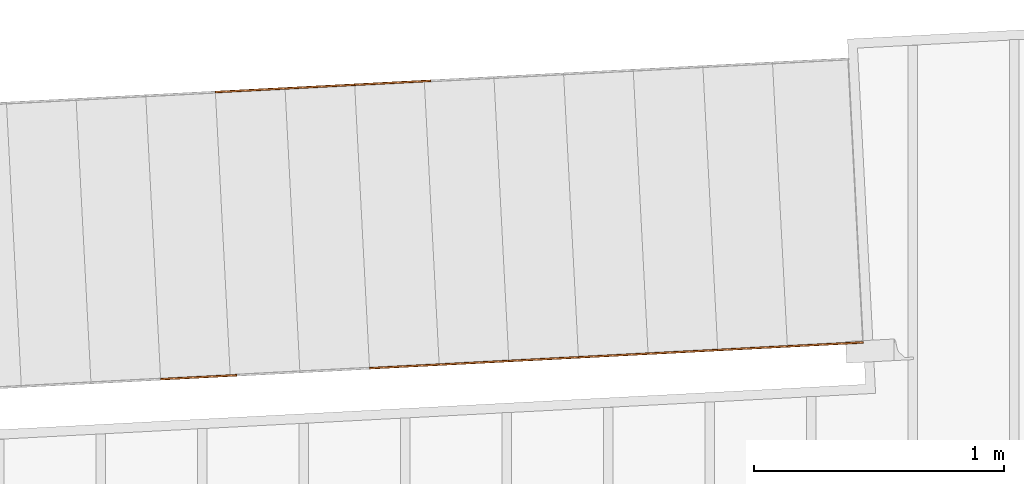
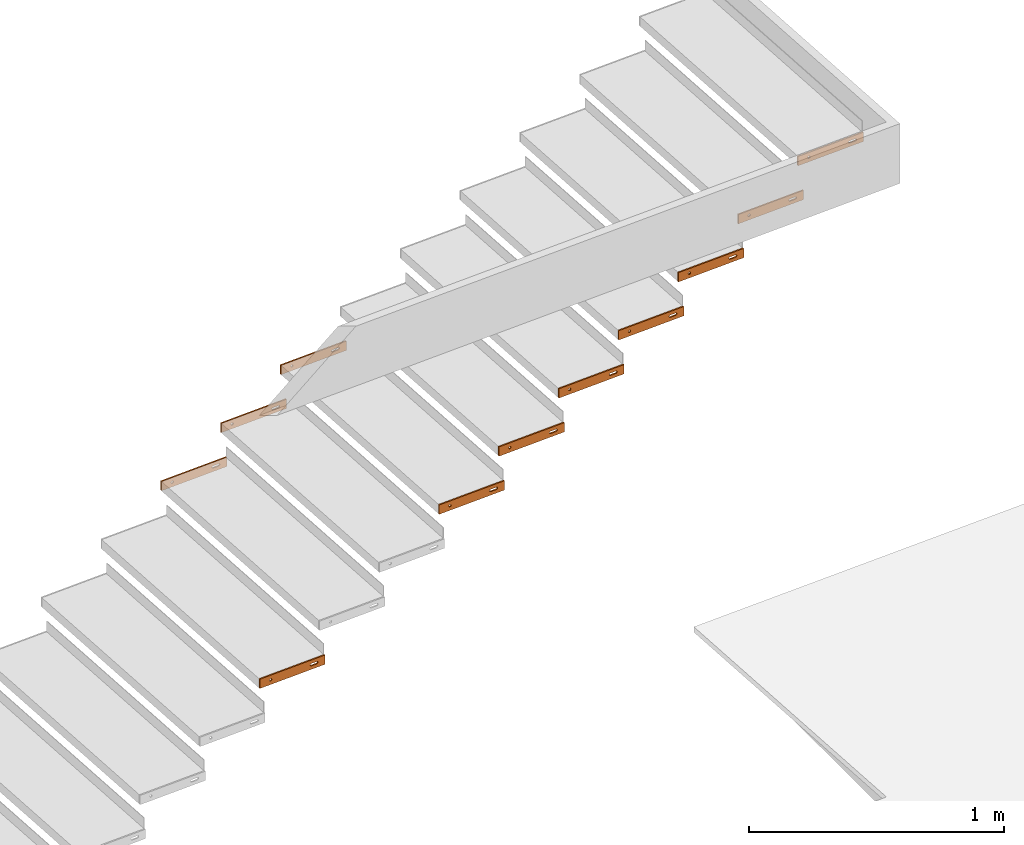
# One storey, part 18 of 23: 11 proxies.
"""IFC4 building model written with IfcOpenShell, lengths in feet."""

import ifcopenshell
import ifcopenshell.guid

model = None  # the IFC model being written
_history = None  # IfcOwnerHistory: only IFC2X3 demands one
_inside = {}  # id of a spatial element -> (the spatial element, [elements in it])
_under = {}  # id of a project, library or spatial element -> (it, [spatial elements below it])
_declared = {}  # id of a project -> (the project, [libraries it declares])
_typed = {}  # id of a type object -> (the type object, [elements of that type])
_made_of = {}  # id of a material, layer set ... -> (it, [elements and type objects made of it])


def new_model(schema):
    """Start an empty IFC model of exactly this schema.

    Asked for "IFC4X3", IfcOpenShell would pick the latest addendum, in which some entities
    have other attributes; the version numbers below select the first issue.
    IFC2X3 requires an IfcOwnerHistory on every rooted entity: one is made here for all.
    """
    global model, _history
    if schema == "IFC4X3":
        model = ifcopenshell.file(schema_version=(4, 3, 0, 0))
    else:
        model = ifcopenshell.file(schema=schema)
    _inside.clear()
    _under.clear()
    _declared.clear()
    _typed.clear()
    _made_of.clear()
    _history = None
    if model.schema == "IFC2X3":
        org = make("IfcOrganization", Name="unknown")
        user = make(
            "IfcPersonAndOrganization",
            ThePerson=make("IfcPerson", FamilyName="unknown"),
            TheOrganization=org,
        )
        app = make(
            "IfcApplication",
            ApplicationDeveloper=org,
            Version="unknown",
            ApplicationFullName="unknown",
            ApplicationIdentifier="unknown",
        )
        _history = make(
            "IfcOwnerHistory",
            OwningUser=user,
            OwningApplication=app,
            ChangeAction="ADDED",
            CreationDate=0,
        )
    return model


def make(cls, **values):
    """One entity of the class cls with the attributes given. An attribute that is None is left unset."""
    return model.create_entity(
        cls, **{name: value for name, value in values.items() if value is not None}
    )


def entity(cls, *values):
    """Any entity or typed value of the class cls, its attributes in the order of the schema. None: left unset."""
    e = model.create_entity(cls)
    for i, value in enumerate(values):
        if value is not None:
            e[i] = value
    return e


def rooted(cls, **values):
    """An entity with a GlobalId (a new one), such as an element, a storey or a relation."""
    return make(cls, GlobalId=ifcopenshell.guid.new(), OwnerHistory=_history, **values)


def si_unit(unit_type, name, prefix=None):
    """IfcSIUnit, for example si_unit("LENGTHUNIT", "METRE", prefix="MILLI")."""
    return make("IfcSIUnit", UnitType=unit_type, Prefix=prefix, Name=name)


def converted_unit(unit_type, name, factor, base, dimensions=None, offset=None):
    """IfcConversionBasedUnit, such as the inch: factor (a typed value) times the base unit."""
    return make(
        "IfcConversionBasedUnit"
        if offset is None
        else "IfcConversionBasedUnitWithOffset",
        ConversionOffset=offset,
        Dimensions=None
        if dimensions is None
        else entity("IfcDimensionalExponents", *dimensions),
        UnitType=unit_type,
        Name=name,
        ConversionFactor=make(
            "IfcMeasureWithUnit", ValueComponent=factor, UnitComponent=base
        ),
    )


def derived_unit(unit_type, elements):
    """IfcDerivedUnit: a product of units, each with its exponent."""
    return make(
        "IfcDerivedUnit",
        Elements=[
            make("IfcDerivedUnitElement", Unit=unit, Exponent=power)
            for unit, power in elements
        ],
        UnitType=unit_type,
    )


def assignment(units):
    """IfcUnitAssignment: the units of a project."""
    return None if units is None else make("IfcUnitAssignment", Units=units)


def point(xyz):
    """IfcCartesianPoint."""
    return None if xyz is None else make("IfcCartesianPoint", Coordinates=xyz)


def direction(xyz):
    """IfcDirection."""
    return None if xyz is None else make("IfcDirection", DirectionRatios=xyz)


def frame(location, z_axis=None, x_axis=None):
    """IfcAxis2Placement3D, a coordinate frame: its origin and axes. An axis left out is left unset."""
    return make(
        "IfcAxis2Placement3D",
        Location=point(location),
        Axis=direction(z_axis),
        RefDirection=direction(x_axis),
    )


def frame_2d(location, x_axis=None):
    """IfcAxis2Placement2D, a coordinate frame in the plane: its origin and x axis."""
    return make(
        "IfcAxis2Placement2D", Location=point(location), RefDirection=direction(x_axis)
    )


def origin():
    """The frame at (0, 0, 0) with its axes left unset."""
    return frame((0.0, 0.0, 0.0))


def place(relative_to, where):
    """IfcLocalPlacement: puts the frame where relative to a parent placement (None: the world)."""
    return make(
        "IfcLocalPlacement", PlacementRelTo=relative_to, RelativePlacement=where
    )


def context(
    kind, dimensions, precision=None, world=None, true_north=None, identifier=None
):
    """IfcGeometricRepresentationContext, for example the 3D "Model" context."""
    return make(
        "IfcGeometricRepresentationContext",
        ContextIdentifier=identifier,
        ContextType=kind,
        CoordinateSpaceDimension=dimensions,
        Precision=precision,
        WorldCoordinateSystem=world,
        TrueNorth=true_north,
    )


def subcontext(parent, identifier, kind, view, scale=None):
    """IfcGeometricRepresentationSubContext, for example "Body" below "Model"."""
    return make(
        "IfcGeometricRepresentationSubContext",
        ContextIdentifier=identifier,
        ContextType=kind,
        ParentContext=parent,
        TargetScale=scale,
        TargetView=view,
    )


def project(units=None, contexts=None):
    """IfcProject with its units and contexts."""
    return rooted(
        "IfcProject",
        Name="project",
        RepresentationContexts=contexts,
        UnitsInContext=assignment(units),
    )


def spatial(cls, under=None, at=None, **own):
    """A site, building, storey or space (cls), placed at a placement, below another one or the project."""
    s = rooted(cls, ObjectPlacement=at, **own)
    if under is not None:
        _under.setdefault(under.id(), (under, []))[1].append(s)
    return s


def polyline(points):
    """IfcPolyline through the points."""
    return make("IfcPolyline", Points=[point(p) for p in points])


def circle_curve(where, radius):
    """IfcCircle in the frame where."""
    return make("IfcCircle", Position=where, Radius=radius)


def parameter(value):
    """IfcParameterValue: where a trimmed curve begins or ends, as a parameter of its basis curve."""
    return model.create_entity("IfcParameterValue", value)


def trimmed(basis, trim1, trim2, sense, master):
    """IfcTrimmedCurve: the piece of a basis curve between two trims."""
    return make(
        "IfcTrimmedCurve",
        BasisCurve=basis,
        Trim1=trim1,
        Trim2=trim2,
        SenseAgreement=sense,
        MasterRepresentation=master,
    )


def segment(curve, same_sense, transition):
    """IfcCompositeCurveSegment."""
    return make(
        "IfcCompositeCurveSegment",
        Transition=transition,
        SameSense=same_sense,
        ParentCurve=curve,
    )


def composite_curve(segments, self_intersect=None):
    """IfcCompositeCurve: segments joined end to end."""
    return make("IfcCompositeCurve", Segments=segments, SelfIntersect=self_intersect)


def outline(outer, holes=None, kind="AREA"):
    """IfcArbitraryClosedProfileDef: a profile drawn as a closed curve; with holes, ...WithVoids."""
    if holes is None:
        return make("IfcArbitraryClosedProfileDef", ProfileType=kind, OuterCurve=outer)
    return make(
        "IfcArbitraryProfileDefWithVoids",
        ProfileType=kind,
        OuterCurve=outer,
        InnerCurves=holes,
    )


def extrude(swept, where, along, depth):
    """IfcExtrudedAreaSolid: the profile swept, set in the frame where, extruded along a direction by depth."""
    return make(
        "IfcExtrudedAreaSolid",
        SweptArea=swept,
        Position=where,
        ExtrudedDirection=direction(along),
        Depth=depth,
    )


def shape(context_of_items, identifier, shape_type, items):
    """IfcShapeRepresentation: the items that make up one representation, for example the "Body"."""
    return make(
        "IfcShapeRepresentation",
        ContextOfItems=context_of_items,
        RepresentationIdentifier=identifier,
        RepresentationType=shape_type,
        Items=items,
    )


def source(mapping_origin, context_of_items, identifier, shape_type, items):
    """IfcRepresentationMap: a shape defined once, which mapped items show again and again."""
    return make(
        "IfcRepresentationMap",
        MappingOrigin=mapping_origin,
        MappedRepresentation=shape(context_of_items, identifier, shape_type, items),
    )


def transform(
    local_origin,
    x_axis=None,
    y_axis=None,
    z_axis=None,
    scale=None,
    scale2=None,
    scale3=None,
    uniform=True,
):
    """IfcCartesianTransformationOperator3D, or its non-uniform kind. x_axis, y_axis, z_axis: its Axis1, 2, 3."""
    if uniform:
        return make(
            "IfcCartesianTransformationOperator3D",
            Axis1=direction(x_axis),
            Axis2=direction(y_axis),
            LocalOrigin=point(local_origin),
            Scale=scale,
            Axis3=direction(z_axis),
        )
    return make(
        "IfcCartesianTransformationOperator3DnonUniform",
        Axis1=direction(x_axis),
        Axis2=direction(y_axis),
        LocalOrigin=point(local_origin),
        Scale=scale,
        Axis3=direction(z_axis),
        Scale2=scale2,
        Scale3=scale3,
    )


def mapped(mapping_source, mapping_target):
    """IfcMappedItem: shows the shape of a source again, moved by a transform."""
    return make(
        "IfcMappedItem", MappingSource=mapping_source, MappingTarget=mapping_target
    )


def material(Name=None, Category=None):
    """IfcMaterial."""
    return make("IfcMaterial", Name=Name, Category=Category)


def made_of(thing, what):
    """Note that an element or type object is made of a material, layer set ...; save() writes the relation."""
    if what is not None:
        _made_of.setdefault(what.id(), (what, []))[1].append(thing)
    return thing


def type_object(cls, material=None, **own):
    """A type object (cls), such as IfcWallType, which elements share."""
    return made_of(rooted(cls, **own), material)


def type_shapes(of_type, sources):
    """Give a type object the sources (RepresentationMaps) that its elements show as mapped items."""
    of_type.RepresentationMaps = sources


def element(
    cls,
    number,
    at=None,
    inside=None,
    cuts=None,
    type_object=None,
    material=None,
    context=None,
    identifier="Body",
    shape_type=None,
    held_by="IfcProductDefinitionShape",
    body=None,
    shapes=None,
    **own,
):
    """One element of the class cls, such as IfcWall. Its Tag is "e" and its number.

    at: its placement. inside: the storey or other place that contains it. cuts: it is an
    opening in that element (IfcRelVoidsElement). A single representation is given by context,
    identifier, shape_type and body (its items); several are given by shapes. held_by: the class
    of the entity that holds the representations. save() writes the other relations.
    """
    e = rooted(cls, Tag="e%d" % number, ObjectPlacement=at, **own)
    if body is not None:
        shapes = [shape(context, identifier, shape_type, body)]
    if shapes is not None:
        e.Representation = make(held_by, Representations=shapes)
    if inside is not None:
        _inside.setdefault(inside.id(), (inside, []))[1].append(e)
    if cuts is not None:
        rooted(
            "IfcRelVoidsElement", RelatingBuildingElement=cuts, RelatedOpeningElement=e
        )
    if type_object is not None:
        _typed.setdefault(type_object.id(), (type_object, []))[1].append(e)
    return made_of(e, material)


def aggregate(whole, parts):
    """IfcRelAggregates: a whole, such as a stair, and the parts it consists of."""
    return rooted("IfcRelAggregates", RelatingObject=whole, RelatedObjects=parts)


def save(model, path):
    """Write the relations noted so far, then the file.

    IfcRelAggregates (storeys below a building ...), IfcRelContainedInSpatialStructure (elements
    in a storey), IfcRelDefinesByType, IfcRelAssociatesMaterial and IfcRelDeclares: one each for
    every whole, place, type object, material and project.
    """
    for whole, parts in _under.values():
        aggregate(whole, parts)
    for where, things in _inside.values():
        rooted(
            "IfcRelContainedInSpatialStructure",
            RelatedElements=things,
            RelatingStructure=where,
        )
    for kind, things in _typed.values():
        rooted("IfcRelDefinesByType", RelatedObjects=things, RelatingType=kind)
    for what, things in _made_of.values():
        rooted("IfcRelAssociatesMaterial", RelatedObjects=things, RelatingMaterial=what)
    for by, libraries in _declared.values():
        rooted("IfcRelDeclares", RelatingContext=by, RelatedDefinitions=libraries)
    model.write(path)


model = new_model("IFC4")

# Units and contexts
model_context = context("Model", 3, precision=0.0001, world=origin(), true_north=direction((6.12303176911189e-17, 1.0)))
body_context = subcontext(model_context, "Body", "Model", "MODEL_VIEW")
ifc_project = project(units=[converted_unit("LENGTHUNIT", "FOOT", entity("IfcRatioMeasure", 0.3048), si_unit("LENGTHUNIT", "METRE"), dimensions=[1, 0, 0, 0, 0, 0, 0]), converted_unit("AREAUNIT", "SQUARE FOOT", entity("IfcRatioMeasure", 0.09290304), si_unit("AREAUNIT", "SQUARE_METRE"), dimensions=[2, 0, 0, 0, 0, 0, 0]), converted_unit("VOLUMEUNIT", "CUBIC FOOT", entity("IfcRatioMeasure", 0.028316846592), si_unit("VOLUMEUNIT", "CUBIC_METRE"), dimensions=[3, 0, 0, 0, 0, 0, 0]), converted_unit("PLANEANGLEUNIT", "DEGREE", entity("IfcRatioMeasure", 0.0174532925199433), si_unit("PLANEANGLEUNIT", "RADIAN"), dimensions=[0, 0, 0, 0, 0, 0, 0]), si_unit("MASSUNIT", "GRAM", prefix="KILO"), derived_unit("MASSDENSITYUNIT", [(si_unit("MASSUNIT", "GRAM", prefix="KILO"), 1), (si_unit("LENGTHUNIT", "METRE"), -3)]), derived_unit("MOMENTOFINERTIAUNIT", [(si_unit("LENGTHUNIT", "METRE"), 4)]), si_unit("TIMEUNIT", "SECOND"), si_unit("FREQUENCYUNIT", "HERTZ"), si_unit("THERMODYNAMICTEMPERATUREUNIT", "DEGREE_CELSIUS"), derived_unit("THERMALTRANSMITTANCEUNIT", [(si_unit("MASSUNIT", "GRAM", prefix="KILO"), 1), (si_unit("THERMODYNAMICTEMPERATUREUNIT", "KELVIN"), -1), (si_unit("TIMEUNIT", "SECOND"), -3)]), derived_unit("VOLUMETRICFLOWRATEUNIT", [(si_unit("LENGTHUNIT", "METRE"), 3), (si_unit("TIMEUNIT", "SECOND"), -1)]), si_unit("ELECTRICCURRENTUNIT", "AMPERE"), si_unit("ELECTRICVOLTAGEUNIT", "VOLT"), si_unit("POWERUNIT", "WATT"), si_unit("FORCEUNIT", "NEWTON"), si_unit("ILLUMINANCEUNIT", "LUX"), si_unit("LUMINOUSFLUXUNIT", "LUMEN"), si_unit("LUMINOUSINTENSITYUNIT", "CANDELA"), derived_unit("USERDEFINED", [(si_unit("MASSUNIT", "GRAM", prefix="KILO"), -1), (si_unit("LENGTHUNIT", "METRE"), -2), (si_unit("TIMEUNIT", "SECOND"), 3), (si_unit("LUMINOUSFLUXUNIT", "LUMEN"), 1)]), derived_unit("LINEARVELOCITYUNIT", [(si_unit("LENGTHUNIT", "METRE"), 1), (si_unit("TIMEUNIT", "SECOND"), -1)]), si_unit("PRESSUREUNIT", "PASCAL"), derived_unit("USERDEFINED", [(si_unit("LENGTHUNIT", "METRE"), -2), (si_unit("MASSUNIT", "GRAM", prefix="KILO"), 1), (si_unit("TIMEUNIT", "SECOND"), -2)]), derived_unit("LINEARFORCEUNIT", [(si_unit("MASSUNIT", "GRAM", prefix="KILO"), 1), (si_unit("LENGTHUNIT", "METRE"), 1), (si_unit("TIMEUNIT", "SECOND"), -2), (si_unit("LENGTHUNIT", "METRE"), -1)]), derived_unit("PLANARFORCEUNIT", [(si_unit("MASSUNIT", "GRAM", prefix="KILO"), 1), (si_unit("LENGTHUNIT", "METRE"), 1), (si_unit("TIMEUNIT", "SECOND"), -2), (si_unit("LENGTHUNIT", "METRE"), -2)])], contexts=[model_context])

# Site, building, storey
site_placement = place(None, origin())
site = spatial("IfcSite", under=ifc_project, at=site_placement, CompositionType="ELEMENT")
building_placement = place(site_placement, origin())
building = spatial("IfcBuilding", under=site, at=building_placement, CompositionType="ELEMENT")
storey_placement = place(building_placement, frame((0.0, 0.0, 10.8020833333333)))
storey = spatial("IfcBuildingStorey", under=building, at=storey_placement, Name="2ND FLOOR", CompositionType="ELEMENT", Elevation=10.8020833333333)

# Proxies
ifc_material = material(Name="GALV. STEEL TREAD", Category="Materials")
building_element_proxy_type_1 = type_object("IfcBuildingElementProxyType", Name="Generic Models 972:Generic Models 629", PredefinedType="NOTDEFINED", material=ifc_material)
shared_shape_1 = source(origin(), body_context, "Body", "SweptSolid", [
    extrude(outline(polyline([(-0.499999999999973, -0.0729166666666679), (0.499999999999967, -0.0729166666666679), (0.500000000000001, 0.0729166666666679), (-0.499999999999967, 0.0729166666666679), (-0.499999999999973, -0.0729166666666679)]), holes=[composite_curve([segment(trimmed(circle_curve(frame_2d((-0.333333333333324, 0.0), x_axis=(-1.0, 0.0)), 0.0182291666666717), [parameter(180.0)], [parameter(360.0)], True, "PARAMETER"), False, "CONTINUOUS"), segment(trimmed(circle_curve(frame_2d((-0.33333333333333, 0.0), x_axis=(-1.0, 0.0)), 0.0182291666666717), [parameter(360.0)], [parameter(180.0)], True, "PARAMETER"), False, "CONTINUOUS")], self_intersect=False), composite_curve([segment(polyline([(0.376206281053262, -0.018229166666675), (0.290460385613239, -0.0182291666667105)]), True, "CONTINUOUS"), segment(trimmed(circle_curve(frame_2d((0.290460385613239, 0.0), x_axis=(1.0, 0.0)), 0.0182291666666714), [parameter(89.999999999957)], [parameter(269.999999999957)], True, "PARAMETER"), False, "CONTINUOUS"), segment(polyline([(0.290460385613245, 0.0182291666666679), (0.376206281053234, 0.0182291666666679)]), True, "CONTINUOUS"), segment(trimmed(circle_curve(frame_2d((0.376206281053262, 0.0), x_axis=(-1.0, 0.0)), 0.0182291666666714), [parameter(90.0000000000894)], [parameter(270.000000000089)], True, "PARAMETER"), False, "CONTINUOUS")], self_intersect=False)]), frame((0.500405099798996, 0.0261679781215207, 0.0729166666666679), z_axis=(-0.0523359562429309, 0.998629534754575, 0.0), x_axis=(0.998629534754575, 0.0523359562429309, 0.0)), (0.0, 0.0, 1.0), 0.0208333333333866),
])
type_shapes(building_element_proxy_type_1, [shared_shape_1])
proxy_1_placement = place(storey_placement, frame((-229.797734568391, 969.063958932095, 6.41392543859647)))
element("IfcBuildingElementProxy", 1, at=proxy_1_placement, inside=storey, type_object=building_element_proxy_type_1, material=ifc_material, Name="Generic Models 972:Generic Models 629", ObjectType="Generic Models 972:Generic Models 629", PredefinedType="NOTDEFINED", context=body_context, shape_type="MappedRepresentation", body=[
    mapped(shared_shape_1, transform((0.0, 0.0, 0.0), scale=1.0)),
])
building_element_proxy_type_2 = type_object("IfcBuildingElementProxyType", Name="Generic Models 973:Generic Models 629", PredefinedType="NOTDEFINED", material=ifc_material)
shared_shape_2 = source(origin(), body_context, "Body", "SweptSolid", [
    extrude(outline(polyline([(-0.499999999999973, -0.0729166666666679), (0.499999999999967, -0.0729166666666679), (0.500000000000001, 0.0729166666666679), (-0.499999999999967, 0.0729166666666679), (-0.499999999999973, -0.0729166666666679)]), holes=[composite_curve([segment(trimmed(circle_curve(frame_2d((-0.33333333333333, 0.0), x_axis=(-1.0, 0.0)), 0.0182291666666717), [parameter(180.0)], [parameter(360.0)], True, "PARAMETER"), False, "CONTINUOUS"), segment(trimmed(circle_curve(frame_2d((-0.333333333333336, 0.0), x_axis=(-1.0, 0.0)), 0.0182291666666717), [parameter(360.0)], [parameter(180.0)], True, "PARAMETER"), False, "CONTINUOUS")], self_intersect=False), composite_curve([segment(polyline([(0.376206281053256, -0.018229166666675), (0.290460385613233, -0.0182291666667105)]), True, "CONTINUOUS"), segment(trimmed(circle_curve(frame_2d((0.290460385613233, 0.0), x_axis=(1.0, 0.0)), 0.0182291666666714), [parameter(89.999999999957)], [parameter(269.999999999957)], True, "PARAMETER"), False, "CONTINUOUS"), segment(polyline([(0.290460385613239, 0.0182291666666679), (0.376206281053228, 0.0182291666666679)]), True, "CONTINUOUS"), segment(trimmed(circle_curve(frame_2d((0.376206281053256, 0.0), x_axis=(-1.0, 0.0)), 0.0182291666666714), [parameter(90.0000000000894)], [parameter(270.000000000089)], True, "PARAMETER"), False, "CONTINUOUS")], self_intersect=False)]), frame((0.500405099798996, 0.0261679781215207, 0.0729166666666679), z_axis=(-0.0523359562429309, 0.998629534754575, 0.0), x_axis=(0.998629534754575, 0.0523359562429309, 0.0)), (0.0, 0.0, 1.0), 0.0208333333333866),
])
type_shapes(building_element_proxy_type_2, [shared_shape_2])
proxy_2_placement = place(storey_placement, frame((-230.712606310766, 969.016012535749, 5.85252192982451)))
element("IfcBuildingElementProxy", 2, at=proxy_2_placement, inside=storey, type_object=building_element_proxy_type_2, material=ifc_material, Name="Generic Models 973:Generic Models 629", ObjectType="Generic Models 973:Generic Models 629", PredefinedType="NOTDEFINED", context=body_context, shape_type="MappedRepresentation", body=[
    mapped(shared_shape_2, transform((0.0, 0.0, 0.0), scale=1.0)),
])
building_element_proxy_type_3 = type_object("IfcBuildingElementProxyType", Name="Generic Models 974:Generic Models 629", PredefinedType="NOTDEFINED", material=ifc_material)
shared_shape_3 = source(origin(), body_context, "Body", "SweptSolid", [
    extrude(outline(polyline([(-0.499999999999973, -0.0729166666666679), (0.499999999999967, -0.0729166666666679), (0.500000000000001, 0.0729166666666679), (-0.499999999999967, 0.0729166666666679), (-0.499999999999973, -0.0729166666666679)]), holes=[composite_curve([segment(trimmed(circle_curve(frame_2d((-0.33333333333333, 0.0), x_axis=(-1.0, 0.0)), 0.0182291666666717), [parameter(180.0)], [parameter(360.0)], True, "PARAMETER"), False, "CONTINUOUS"), segment(trimmed(circle_curve(frame_2d((-0.333333333333336, 0.0), x_axis=(-1.0, 0.0)), 0.0182291666666717), [parameter(360.0)], [parameter(180.0)], True, "PARAMETER"), False, "CONTINUOUS")], self_intersect=False), composite_curve([segment(polyline([(0.376206281053256, -0.018229166666675), (0.290460385613233, -0.0182291666667105)]), True, "CONTINUOUS"), segment(trimmed(circle_curve(frame_2d((0.290460385613233, 0.0), x_axis=(1.0, 0.0)), 0.0182291666666714), [parameter(89.999999999957)], [parameter(269.999999999957)], True, "PARAMETER"), False, "CONTINUOUS"), segment(polyline([(0.290460385613239, 0.0182291666666679), (0.376206281053228, 0.0182291666666679)]), True, "CONTINUOUS"), segment(trimmed(circle_curve(frame_2d((0.376206281053256, 0.0), x_axis=(-1.0, 0.0)), 0.0182291666666714), [parameter(90.0000000000894)], [parameter(270.000000000089)], True, "PARAMETER"), False, "CONTINUOUS")], self_intersect=False)]), frame((0.500405099798996, 0.0261679781216344, 0.0729166666666679), z_axis=(-0.0523359562429309, 0.998629534754575, 0.0), x_axis=(0.998629534754575, 0.0523359562429309, 0.0)), (0.0, 0.0, 1.0), 0.0208333333333866),
])
type_shapes(building_element_proxy_type_3, [shared_shape_3])
proxy_3_placement = place(storey_placement, frame((-231.627478053141, 968.968066139402, 5.29111842105256)))
element("IfcBuildingElementProxy", 3, at=proxy_3_placement, inside=storey, type_object=building_element_proxy_type_3, material=ifc_material, Name="Generic Models 974:Generic Models 629", ObjectType="Generic Models 974:Generic Models 629", PredefinedType="NOTDEFINED", context=body_context, shape_type="MappedRepresentation", body=[
    mapped(shared_shape_3, transform((0.0, 0.0, 0.0), scale=1.0)),
])
building_element_proxy_type_4 = type_object("IfcBuildingElementProxyType", Name="Generic Models 890:Generic Models 629", PredefinedType="NOTDEFINED", material=ifc_material)
shared_shape_4 = source(origin(), body_context, "Body", "SweptSolid", [
    extrude(outline(polyline([(-0.499999999999979, -0.0729166666666679), (0.499999999999961, -0.0729166666666679), (0.499999999999973, 0.0729166666666679), (-0.499999999999967, 0.0729166666666679), (-0.499999999999979, -0.0729166666666679)]), holes=[composite_curve([segment(trimmed(circle_curve(frame_2d((-0.333333333333308, 0.0), x_axis=(-1.0, 0.0)), 0.0182291666666717), [parameter(180.0)], [parameter(360.0)], True, "PARAMETER"), False, "CONTINUOUS"), segment(trimmed(circle_curve(frame_2d((-0.333333333333308, 0.0), x_axis=(-1.0, 0.0)), 0.0182291666666717), [parameter(360.0)], [parameter(180.0)], True, "PARAMETER"), False, "CONTINUOUS")], self_intersect=False), composite_curve([segment(polyline([(0.37620628105325, -0.018229166666675), (0.29046038561329, -0.0182291666667105)]), True, "CONTINUOUS"), segment(trimmed(circle_curve(frame_2d((0.29046038561329, 0.0), x_axis=(1.0, 0.0)), 0.0182291666666714), [parameter(89.999999999957)], [parameter(269.999999999957)], True, "PARAMETER"), False, "CONTINUOUS"), segment(polyline([(0.29046038561329, 0.0182291666666679), (0.376206281053256, 0.0182291666666679)]), True, "CONTINUOUS"), segment(trimmed(circle_curve(frame_2d((0.376206281053256, 0.0), x_axis=(-1.0, 0.0)), 0.0182291666666714), [parameter(90.0000000000002)], [parameter(270.0)], True, "PARAMETER"), False, "CONTINUOUS")], self_intersect=False)]), frame((0.500405099799025, 0.0261679781216344, 0.0729166666666679), z_axis=(-0.0523359562429309, 0.998629534754575, 0.0), x_axis=(0.998629534754575, 0.0523359562429309, 0.0)), (0.0, 0.0, 1.0), 0.0208333333333866),
])
type_shapes(building_element_proxy_type_4, [shared_shape_4])
proxy_4_placement = place(storey_placement, frame((-229.602565064899, 965.339902958694, 6.41392543859251)))
element("IfcBuildingElementProxy", 4, at=proxy_4_placement, inside=storey, type_object=building_element_proxy_type_4, material=ifc_material, Name="Generic Models 890:Generic Models 629", ObjectType="Generic Models 890:Generic Models 629", PredefinedType="NOTDEFINED", context=body_context, shape_type="MappedRepresentation", body=[
    mapped(shared_shape_4, transform((0.0, 0.0, 0.0), scale=1.0)),
])
building_element_proxy_type_5 = type_object("IfcBuildingElementProxyType", Name="Generic Models 892:Generic Models 629", PredefinedType="NOTDEFINED", material=ifc_material)
shared_shape_5 = source(origin(), body_context, "Body", "SweptSolid", [
    extrude(outline(polyline([(-0.499999999999973, -0.0729166666666679), (0.499999999999967, -0.0729166666666679), (0.499999999999979, 0.0729166666666679), (-0.499999999999961, 0.0729166666666679), (-0.499999999999973, -0.0729166666666679)]), holes=[composite_curve([segment(trimmed(circle_curve(frame_2d((-0.333333333333302, 0.0), x_axis=(-1.0, 0.0)), 0.0182291666666717), [parameter(180.0)], [parameter(360.0)], True, "PARAMETER"), False, "CONTINUOUS"), segment(trimmed(circle_curve(frame_2d((-0.333333333333302, 0.0), x_axis=(-1.0, 0.0)), 0.0182291666666717), [parameter(360.0)], [parameter(180.0)], True, "PARAMETER"), False, "CONTINUOUS")], self_intersect=False), composite_curve([segment(polyline([(0.376206281053256, -0.018229166666675), (0.290460385613296, -0.0182291666667105)]), True, "CONTINUOUS"), segment(trimmed(circle_curve(frame_2d((0.290460385613296, 0.0), x_axis=(1.0, 0.0)), 0.0182291666666714), [parameter(89.999999999957)], [parameter(269.999999999957)], True, "PARAMETER"), False, "CONTINUOUS"), segment(polyline([(0.290460385613296, 0.0182291666666679), (0.376206281053262, 0.0182291666666679)]), True, "CONTINUOUS"), segment(trimmed(circle_curve(frame_2d((0.376206281053262, 0.0), x_axis=(-1.0, 0.0)), 0.0182291666666714), [parameter(90.0000000000002)], [parameter(270.0)], True, "PARAMETER"), False, "CONTINUOUS")], self_intersect=False)]), frame((0.500405099799025, 0.0261679781215207, 0.0729166666666679), z_axis=(-0.0523359562429309, 0.998629534754575, 0.0), x_axis=(0.998629534754575, 0.0523359562429309, 0.0)), (0.0, 0.0, 1.0), 0.0208333333333866),
])
type_shapes(building_element_proxy_type_5, [shared_shape_5])
proxy_5_placement = place(storey_placement, frame((-224.113334610648, 965.627581336774, 9.78234649122425)))
element("IfcBuildingElementProxy", 5, at=proxy_5_placement, inside=storey, type_object=building_element_proxy_type_5, material=ifc_material, Name="Generic Models 892:Generic Models 629", ObjectType="Generic Models 892:Generic Models 629", PredefinedType="NOTDEFINED", context=body_context, shape_type="MappedRepresentation", body=[
    mapped(shared_shape_5, transform((0.0, 0.0, 0.0), scale=1.0)),
])
building_element_proxy_type_6 = type_object("IfcBuildingElementProxyType", Name="Generic Models 894:Generic Models 629", PredefinedType="NOTDEFINED", material=ifc_material)
shared_shape_6 = source(origin(), body_context, "Body", "SweptSolid", [
    extrude(outline(polyline([(-0.499999999999973, -0.0729166666666679), (0.499999999999967, -0.0729166666666679), (0.499999999999979, 0.0729166666666679), (-0.499999999999961, 0.0729166666666679), (-0.499999999999973, -0.0729166666666679)]), holes=[composite_curve([segment(trimmed(circle_curve(frame_2d((-0.333333333333302, 0.0), x_axis=(-1.0, 0.0)), 0.0182291666666717), [parameter(180.0)], [parameter(360.0)], True, "PARAMETER"), False, "CONTINUOUS"), segment(trimmed(circle_curve(frame_2d((-0.333333333333302, 0.0), x_axis=(-1.0, 0.0)), 0.0182291666666717), [parameter(360.0)], [parameter(180.0)], True, "PARAMETER"), False, "CONTINUOUS")], self_intersect=False), composite_curve([segment(polyline([(0.376206281053256, -0.018229166666675), (0.290460385613296, -0.0182291666667105)]), True, "CONTINUOUS"), segment(trimmed(circle_curve(frame_2d((0.290460385613296, 0.0), x_axis=(1.0, 0.0)), 0.0182291666666714), [parameter(89.999999999957)], [parameter(269.999999999957)], True, "PARAMETER"), False, "CONTINUOUS"), segment(polyline([(0.290460385613296, 0.0182291666666679), (0.376206281053262, 0.0182291666666679)]), True, "CONTINUOUS"), segment(trimmed(circle_curve(frame_2d((0.376206281053262, 0.0), x_axis=(-1.0, 0.0)), 0.0182291666666714), [parameter(90.0000000000002)], [parameter(270.0)], True, "PARAMETER"), False, "CONTINUOUS")], self_intersect=False)]), frame((0.500405099799025, 0.0261679781215207, 0.0729166666666679), z_axis=(-0.0523359562429309, 0.998629534754575, 0.0), x_axis=(0.998629534754575, 0.0523359562429309, 0.0)), (0.0, 0.0, 1.0), 0.0208333333333866),
])
type_shapes(building_element_proxy_type_6, [shared_shape_6])
proxy_6_placement = place(storey_placement, frame((-225.028206353023, 965.579634940428, 9.2209429824523)))
element("IfcBuildingElementProxy", 6, at=proxy_6_placement, inside=storey, type_object=building_element_proxy_type_6, material=ifc_material, Name="Generic Models 894:Generic Models 629", ObjectType="Generic Models 894:Generic Models 629", PredefinedType="NOTDEFINED", context=body_context, shape_type="MappedRepresentation", body=[
    mapped(shared_shape_6, transform((0.0, 0.0, 0.0), scale=1.0)),
])
building_element_proxy_type_7 = type_object("IfcBuildingElementProxyType", Name="Generic Models 896:Generic Models 629", PredefinedType="NOTDEFINED", material=ifc_material)
shared_shape_7 = source(origin(), body_context, "Body", "SweptSolid", [
    extrude(outline(polyline([(-0.499999999999979, -0.0729166666666679), (0.499999999999961, -0.0729166666666679), (0.499999999999973, 0.0729166666666679), (-0.499999999999967, 0.0729166666666679), (-0.499999999999979, -0.0729166666666679)]), holes=[composite_curve([segment(trimmed(circle_curve(frame_2d((-0.333333333333308, 0.0), x_axis=(-1.0, 0.0)), 0.0182291666666717), [parameter(180.0)], [parameter(360.0)], True, "PARAMETER"), False, "CONTINUOUS"), segment(trimmed(circle_curve(frame_2d((-0.333333333333308, 0.0), x_axis=(-1.0, 0.0)), 0.0182291666666717), [parameter(360.0)], [parameter(180.0)], True, "PARAMETER"), False, "CONTINUOUS")], self_intersect=False), composite_curve([segment(polyline([(0.37620628105325, -0.018229166666675), (0.29046038561329, -0.0182291666667105)]), True, "CONTINUOUS"), segment(trimmed(circle_curve(frame_2d((0.29046038561329, 0.0), x_axis=(1.0, 0.0)), 0.0182291666666714), [parameter(89.999999999957)], [parameter(269.999999999957)], True, "PARAMETER"), False, "CONTINUOUS"), segment(polyline([(0.29046038561329, 0.0182291666666679), (0.376206281053256, 0.0182291666666679)]), True, "CONTINUOUS"), segment(trimmed(circle_curve(frame_2d((0.376206281053256, 0.0), x_axis=(-1.0, 0.0)), 0.0182291666666714), [parameter(90.0000000000002)], [parameter(270.0)], True, "PARAMETER"), False, "CONTINUOUS")], self_intersect=False)]), frame((0.500405099799025, 0.0261679781216344, 0.0729166666666679), z_axis=(-0.0523359562429309, 0.998629534754575, 0.0), x_axis=(0.998629534754575, 0.0523359562429309, 0.0)), (0.0, 0.0, 1.0), 0.0208333333333866),
])
type_shapes(building_element_proxy_type_7, [shared_shape_7])
proxy_7_placement = place(storey_placement, frame((-225.943078095398, 965.531688544081, 8.65953947368034)))
element("IfcBuildingElementProxy", 7, at=proxy_7_placement, inside=storey, type_object=building_element_proxy_type_7, material=ifc_material, Name="Generic Models 896:Generic Models 629", ObjectType="Generic Models 896:Generic Models 629", PredefinedType="NOTDEFINED", context=body_context, shape_type="MappedRepresentation", body=[
    mapped(shared_shape_7, transform((0.0, 0.0, 0.0), scale=1.0)),
])
building_element_proxy_type_8 = type_object("IfcBuildingElementProxyType", Name="Generic Models 898:Generic Models 629", PredefinedType="NOTDEFINED", material=ifc_material)
shared_shape_8 = source(origin(), body_context, "Body", "SweptSolid", [
    extrude(outline(polyline([(-0.499999999999973, -0.0729166666666679), (0.499999999999967, -0.0729166666666679), (0.499999999999979, 0.0729166666666679), (-0.499999999999961, 0.0729166666666679), (-0.499999999999973, -0.0729166666666679)]), holes=[composite_curve([segment(trimmed(circle_curve(frame_2d((-0.333333333333302, 0.0), x_axis=(-1.0, 0.0)), 0.0182291666666717), [parameter(180.0)], [parameter(360.0)], True, "PARAMETER"), False, "CONTINUOUS"), segment(trimmed(circle_curve(frame_2d((-0.333333333333302, 0.0), x_axis=(-1.0, 0.0)), 0.0182291666666717), [parameter(360.0)], [parameter(180.0)], True, "PARAMETER"), False, "CONTINUOUS")], self_intersect=False), composite_curve([segment(polyline([(0.376206281053256, -0.018229166666675), (0.290460385613296, -0.0182291666667105)]), True, "CONTINUOUS"), segment(trimmed(circle_curve(frame_2d((0.290460385613296, 0.0), x_axis=(1.0, 0.0)), 0.0182291666666714), [parameter(89.999999999957)], [parameter(269.999999999957)], True, "PARAMETER"), False, "CONTINUOUS"), segment(polyline([(0.290460385613296, 0.0182291666666679), (0.376206281053262, 0.0182291666666679)]), True, "CONTINUOUS"), segment(trimmed(circle_curve(frame_2d((0.376206281053262, 0.0), x_axis=(-1.0, 0.0)), 0.0182291666666714), [parameter(90.0000000000002)], [parameter(270.0)], True, "PARAMETER"), False, "CONTINUOUS")], self_intersect=False)]), frame((0.500405099799025, 0.0261679781215207, 0.0729166666666679), z_axis=(-0.0523359562429309, 0.998629534754575, 0.0), x_axis=(0.998629534754575, 0.0523359562429309, 0.0)), (0.0, 0.0, 1.0), 0.0208333333333866),
])
type_shapes(building_element_proxy_type_8, [shared_shape_8])
proxy_8_placement = place(storey_placement, frame((-226.857949837773, 965.483742147734, 8.09813596490839)))
element("IfcBuildingElementProxy", 8, at=proxy_8_placement, inside=storey, type_object=building_element_proxy_type_8, material=ifc_material, Name="Generic Models 898:Generic Models 629", ObjectType="Generic Models 898:Generic Models 629", PredefinedType="NOTDEFINED", context=body_context, shape_type="MappedRepresentation", body=[
    mapped(shared_shape_8, transform((0.0, 0.0, 0.0), scale=1.0)),
])
building_element_proxy_type_9 = type_object("IfcBuildingElementProxyType", Name="Generic Models 900:Generic Models 629", PredefinedType="NOTDEFINED", material=ifc_material)
shared_shape_9 = source(origin(), body_context, "Body", "SweptSolid", [
    extrude(outline(polyline([(-0.499999999999973, -0.0729166666666679), (0.499999999999967, -0.0729166666666679), (0.499999999999979, 0.0729166666666679), (-0.499999999999961, 0.0729166666666679), (-0.499999999999973, -0.0729166666666679)]), holes=[composite_curve([segment(trimmed(circle_curve(frame_2d((-0.333333333333302, 0.0), x_axis=(-1.0, 0.0)), 0.0182291666666717), [parameter(180.0)], [parameter(360.0)], True, "PARAMETER"), False, "CONTINUOUS"), segment(trimmed(circle_curve(frame_2d((-0.333333333333302, 0.0), x_axis=(-1.0, 0.0)), 0.0182291666666717), [parameter(360.0)], [parameter(180.0)], True, "PARAMETER"), False, "CONTINUOUS")], self_intersect=False), composite_curve([segment(polyline([(0.376206281053256, -0.018229166666675), (0.290460385613296, -0.0182291666667105)]), True, "CONTINUOUS"), segment(trimmed(circle_curve(frame_2d((0.290460385613296, 0.0), x_axis=(1.0, 0.0)), 0.0182291666666714), [parameter(89.999999999957)], [parameter(269.999999999957)], True, "PARAMETER"), False, "CONTINUOUS"), segment(polyline([(0.290460385613296, 0.0182291666666679), (0.376206281053262, 0.0182291666666679)]), True, "CONTINUOUS"), segment(trimmed(circle_curve(frame_2d((0.376206281053262, 0.0), x_axis=(-1.0, 0.0)), 0.0182291666666714), [parameter(90.0000000000002)], [parameter(270.0)], True, "PARAMETER"), False, "CONTINUOUS")], self_intersect=False)]), frame((0.500405099799025, 0.0261679781215207, 0.0729166666666679), z_axis=(-0.0523359562429309, 0.998629534754575, 0.0), x_axis=(0.998629534754575, 0.0523359562429309, 0.0)), (0.0, 0.0, 1.0), 0.0208333333333866),
])
type_shapes(building_element_proxy_type_9, [shared_shape_9])
proxy_9_placement = place(storey_placement, frame((-227.772821580149, 965.435795751388, 7.53673245613643)))
element("IfcBuildingElementProxy", 9, at=proxy_9_placement, inside=storey, type_object=building_element_proxy_type_9, material=ifc_material, Name="Generic Models 900:Generic Models 629", ObjectType="Generic Models 900:Generic Models 629", PredefinedType="NOTDEFINED", context=body_context, shape_type="MappedRepresentation", body=[
    mapped(shared_shape_9, transform((0.0, 0.0, 0.0), scale=1.0)),
])
building_element_proxy_type_10 = type_object("IfcBuildingElementProxyType", Name="Generic Models 902:Generic Models 629", PredefinedType="NOTDEFINED", material=ifc_material)
shared_shape_10 = source(origin(), body_context, "Body", "SweptSolid", [
    extrude(outline(polyline([(-0.499999999999973, -0.0729166666666679), (0.499999999999967, -0.0729166666666679), (0.499999999999979, 0.0729166666666679), (-0.499999999999961, 0.0729166666666679), (-0.499999999999973, -0.0729166666666679)]), holes=[composite_curve([segment(trimmed(circle_curve(frame_2d((-0.333333333333302, 0.0), x_axis=(-1.0, 0.0)), 0.0182291666666717), [parameter(180.0)], [parameter(360.0)], True, "PARAMETER"), False, "CONTINUOUS"), segment(trimmed(circle_curve(frame_2d((-0.333333333333302, 0.0), x_axis=(-1.0, 0.0)), 0.0182291666666717), [parameter(360.0)], [parameter(180.0)], True, "PARAMETER"), False, "CONTINUOUS")], self_intersect=False), composite_curve([segment(polyline([(0.376206281053256, -0.018229166666675), (0.290460385613296, -0.0182291666667105)]), True, "CONTINUOUS"), segment(trimmed(circle_curve(frame_2d((0.290460385613296, 0.0), x_axis=(1.0, 0.0)), 0.0182291666666714), [parameter(89.999999999957)], [parameter(269.999999999957)], True, "PARAMETER"), False, "CONTINUOUS"), segment(polyline([(0.290460385613296, 0.0182291666666679), (0.376206281053262, 0.0182291666666679)]), True, "CONTINUOUS"), segment(trimmed(circle_curve(frame_2d((0.376206281053262, 0.0), x_axis=(-1.0, 0.0)), 0.0182291666666714), [parameter(90.0000000000002)], [parameter(270.0)], True, "PARAMETER"), False, "CONTINUOUS")], self_intersect=False)]), frame((0.500405099799025, 0.0261679781215207, 0.0729166666666679), z_axis=(-0.0523359562429309, 0.998629534754575, 0.0), x_axis=(0.998629534754575, 0.0523359562429309, 0.0)), (0.0, 0.0, 1.0), 0.0208333333333866),
])
type_shapes(building_element_proxy_type_10, [shared_shape_10])
proxy_10_placement = place(storey_placement, frame((-228.687693322524, 965.387849355041, 6.97532894736447)))
element("IfcBuildingElementProxy", 10, at=proxy_10_placement, inside=storey, type_object=building_element_proxy_type_10, material=ifc_material, Name="Generic Models 902:Generic Models 629", ObjectType="Generic Models 902:Generic Models 629", PredefinedType="NOTDEFINED", context=body_context, shape_type="MappedRepresentation", body=[
    mapped(shared_shape_10, transform((0.0, 0.0, 0.0), scale=1.0)),
])
building_element_proxy_type_11 = type_object("IfcBuildingElementProxyType", Name="Generic Models 908:Generic Models 629", PredefinedType="NOTDEFINED", material=ifc_material)
shared_shape_11 = source(origin(), body_context, "Body", "SweptSolid", [
    extrude(outline(polyline([(-0.499999999999973, -0.0729166666666679), (0.499999999999967, -0.0729166666666679), (0.499999999999979, 0.0729166666666679), (-0.499999999999961, 0.0729166666666679), (-0.499999999999973, -0.0729166666666679)]), holes=[composite_curve([segment(trimmed(circle_curve(frame_2d((-0.333333333333302, 0.0), x_axis=(-1.0, 0.0)), 0.0182291666666717), [parameter(180.0)], [parameter(360.0)], True, "PARAMETER"), False, "CONTINUOUS"), segment(trimmed(circle_curve(frame_2d((-0.333333333333302, 0.0), x_axis=(-1.0, 0.0)), 0.0182291666666717), [parameter(360.0)], [parameter(180.0)], True, "PARAMETER"), False, "CONTINUOUS")], self_intersect=False), composite_curve([segment(polyline([(0.376206281053256, -0.0182291666666732), (0.290460385613296, -0.0182291666667105)]), True, "CONTINUOUS"), segment(trimmed(circle_curve(frame_2d((0.290460385613296, 0.0), x_axis=(1.0, 0.0)), 0.0182291666666714), [parameter(89.999999999957)], [parameter(269.999999999957)], True, "PARAMETER"), False, "CONTINUOUS"), segment(polyline([(0.290460385613296, 0.0182291666666696), (0.376206281053262, 0.0182291666666679)]), True, "CONTINUOUS"), segment(trimmed(circle_curve(frame_2d((0.376206281053262, 0.0), x_axis=(-1.0, 0.0)), 0.0182291666666714), [parameter(90.0000000000002)], [parameter(270.0)], True, "PARAMETER"), False, "CONTINUOUS")], self_intersect=False)]), frame((0.500405099799025, 0.0261679781215207, 0.0729166666666679), z_axis=(-0.0523359562429309, 0.998629534754575, 0.0), x_axis=(0.998629534754575, 0.0523359562429309, 0.0)), (0.0, 0.0, 1.0), 0.0208333333333866),
])
type_shapes(building_element_proxy_type_11, [shared_shape_11])
proxy_11_placement = place(storey_placement, frame((-232.347180292025, 965.196063769654, 4.72971491227665)))
element("IfcBuildingElementProxy", 11, at=proxy_11_placement, inside=storey, type_object=building_element_proxy_type_11, material=ifc_material, Name="Generic Models 908:Generic Models 629", ObjectType="Generic Models 908:Generic Models 629", PredefinedType="NOTDEFINED", context=body_context, shape_type="MappedRepresentation", body=[
    mapped(shared_shape_11, transform((0.0, 0.0, 0.0), scale=1.0)),
])

save(model, "model.ifc")
